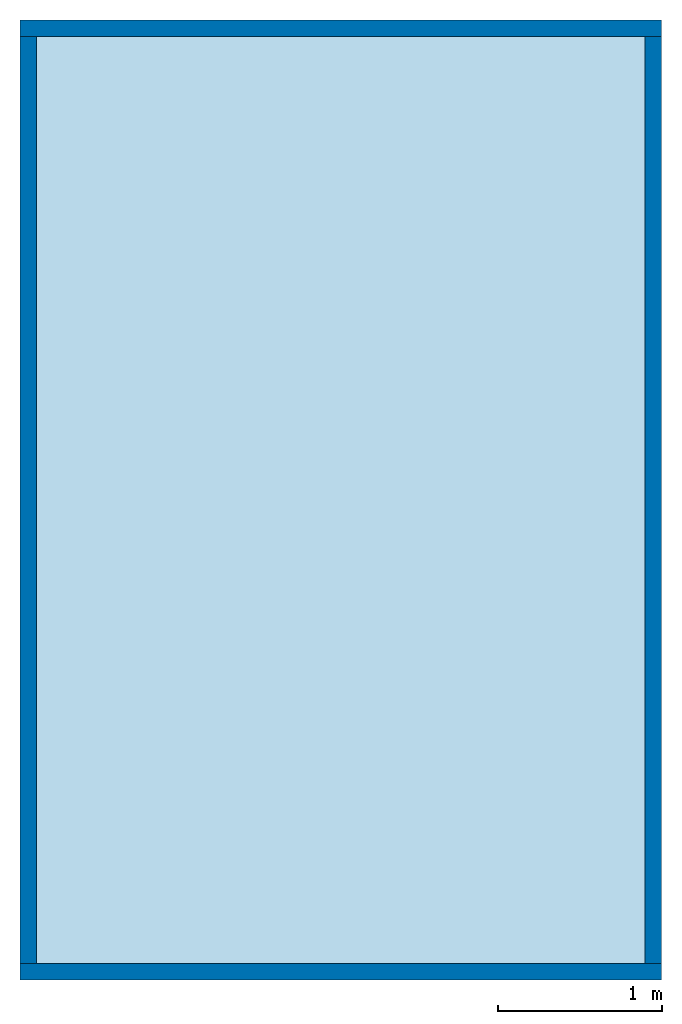
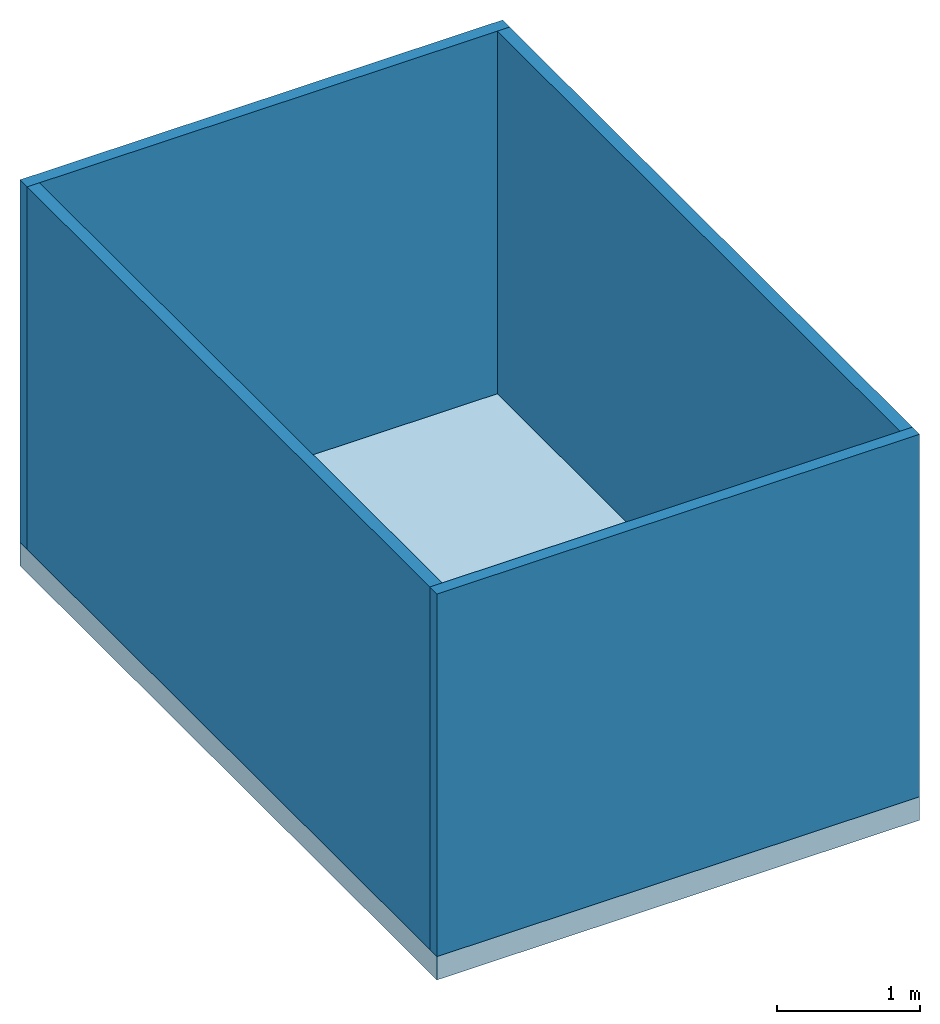
# One storey: 4 walls, 1 slab, 1 element without a shape of its own.
"""IFC4 building model written with IfcOpenShell, lengths in metres."""

from ifc_helpers import new_model, entity, si_unit, converted_unit, frame, origin_with_axes, origin_2d_with_axis, place, context, subcontext, project, spatial, line, indexed_curve, outline, extrude, clip, halfspace, material, layer, layer_set, layer_usage, type_object, element, aggregate, save


model = new_model("IFC4")

# Units and contexts
model_context = context("Model", 3, precision=1e-05, world=origin_with_axes())
plan_context = context("Plan", 2, precision=1e-05, world=origin_2d_with_axis())
body_context = subcontext(model_context, "Body", "Model", "MODEL_VIEW")
ifc_project = project(units=[si_unit("VOLUMEUNIT", "CUBIC_METRE"), si_unit("LENGTHUNIT", "METRE"), converted_unit("PLANEANGLEUNIT", "degree", entity("IfcReal", 0.0174532925199433), si_unit("PLANEANGLEUNIT", "RADIAN"), dimensions=[0, 0, 0, 0, 0, 0, 0]), si_unit("AREAUNIT", "SQUARE_METRE")], contexts=[model_context, plan_context])

# Site, building, storey
site_placement = place(None, origin_with_axes())
site = spatial("IfcSite", under=ifc_project, at=site_placement)
building_placement = place(site_placement, origin_with_axes())
building = spatial("IfcBuilding", under=site, at=building_placement, Name="Building")
storey_placement = place(building_placement, origin_with_axes())
storey = spatial("IfcBuildingStorey", under=building, at=storey_placement, Name="GF")

# Slab
ifc_material = material()
ifc_layer_1 = layer(ifc_material, 0.200000002980232)
ifc_layer_set_1 = layer_set([ifc_layer_1])
ifc_layer_usage_1 = layer_usage(ifc_layer_set_1, "AXIS3", "POSITIVE", 0.0)
slab_type = type_object("IfcSlabType", Name="slab", PredefinedType="FLOOR", material=ifc_layer_set_1)
slab_placement = place(storey_placement, frame((0.0, 0.0, -0.200000002980232), z_axis=(0.0, 0.0, 1.0), x_axis=(1.0, 0.0, 0.0)))
element("IfcSlab", 1, at=slab_placement, inside=storey, type_object=slab_type, material=ifc_layer_usage_1, Name="Slab", context=body_context, shape_type="SweptSolid", body=[
    extrude(outline(indexed_curve([(0.0, 0.0), (3.90270328521729, 0.0), (3.90270328521729, 5.84088945388794), (0.0, 5.84088945388794)], segments=[line(3, 2), line(2, 1), line(1, 4), line(4, 3)], self_intersect=False)), None, (0.0, 0.0, 1.0), 0.200000002980232),
])

# Assembly, walls
assembly_placement = place(storey_placement, origin_with_axes())
assembly = element("IfcElementAssembly", 2, at=assembly_placement, inside=storey)
ifc_layer_2 = layer(ifc_material, 0.1)
ifc_layer_set_2 = layer_set([ifc_layer_2])
ifc_layer_usage_2 = layer_usage(ifc_layer_set_2, "AXIS2", "POSITIVE", 0.0)
wall_type = type_object("IfcWallType", Name="wall", PredefinedType="SOLIDWALL", material=ifc_layer_set_2)
wall_1_placement = place(assembly_placement, origin_with_axes())
wall_1 = element("IfcWall", 3, at=wall_1_placement, type_object=wall_type, material=ifc_layer_usage_2, Name="Wall", context=body_context, shape_type="Clipping", body=[
    clip(extrude(outline(indexed_curve([(0.0, 0.0), (0.0, 0.1), (3.90270334597408, 0.1), (3.90270334597408, 0.0), (0.0, 0.0)], self_intersect=False)), origin_with_axes(), (0.0, 0.0, 1.0), 3.1000000984438), halfspace(frame((0.0, 0.0, 3.10000014305115), z_axis=(0.0, 0.0, 1.0), x_axis=(-1.0, 0.0, 0.0)), False)),
])
ifc_layer_usage_3 = layer_usage(ifc_layer_set_2, "AXIS2", "POSITIVE", 0.0)
wall_2_placement = place(assembly_placement, frame((0.0, 5.74088954925537, 0.0), z_axis=(0.0, 0.0, 1.0), x_axis=(1.0, 0.0, 0.0)))
wall_2 = element("IfcWall", 4, at=wall_2_placement, type_object=wall_type, material=ifc_layer_usage_3, Name="Wall", context=body_context, shape_type="Clipping", body=[
    clip(extrude(outline(indexed_curve([(0.0, 0.0), (0.0, 0.1), (3.90270334597408, 0.1), (3.90270334597408, 0.0), (0.0, 0.0)], self_intersect=False)), origin_with_axes(), (0.0, 0.0, 1.0), 3.1000000984438), halfspace(frame((0.0, 0.0, 3.10000014305115), z_axis=(0.0, 0.0, 1.0), x_axis=(-1.0, 0.0, 0.0)), False)),
])
ifc_layer_usage_4 = layer_usage(ifc_layer_set_2, "AXIS2", "POSITIVE", 0.0)
wall_3_placement = place(assembly_placement, frame((1.71551732819353e-06, 5.74088954925537, 0.0), z_axis=(0.0, 0.0, 1.0), x_axis=(-2.82129974493717e-07, -0.99999999999996, 0.0)))
wall_3 = element("IfcWall", 5, at=wall_3_placement, type_object=wall_type, material=ifc_layer_usage_4, Name="Wall", context=body_context, shape_type="Clipping", body=[
    clip(extrude(outline(indexed_curve([(0.0, 0.0), (0.0, 0.1), (5.6408890849929, 0.1), (5.6408890849929, 0.0), (0.0, 0.0)], self_intersect=False)), origin_with_axes(), (0.0, 0.0, 1.0), 3.1000000984438), halfspace(frame((-4.84057238736568e-13, 0.0, 3.10000014305115), z_axis=(0.0, 0.0, 1.0), x_axis=(-1.0, 0.0, 0.0)), False)),
])
ifc_layer_usage_5 = layer_usage(ifc_layer_set_2, "AXIS2", "POSITIVE", 0.0)
wall_4_placement = place(assembly_placement, frame((3.80270481109619, 5.74088954925537, 0.0), z_axis=(0.0, 0.0, 1.0), x_axis=(-2.82129974493717e-07, -0.99999999999996, 0.0)))
wall_4 = element("IfcWall", 6, at=wall_4_placement, type_object=wall_type, material=ifc_layer_usage_5, Name="Wall", context=body_context, shape_type="Clipping", body=[
    clip(extrude(outline(indexed_curve([(0.0, 0.0), (0.0, 0.1), (5.64088908499292, 0.1), (5.64088908499292, 0.0), (0.0, 0.0)], self_intersect=False)), origin_with_axes(), (0.0, 0.0, 1.0), 3.1000000984438), halfspace(frame((-1.19182686830754e-07, 4.92530034534866e-08, 3.10000014305115), z_axis=(0.0, 0.0, 1.0), x_axis=(-1.0, 0.0, 0.0)), False)),
])
aggregate(assembly, [wall_1, wall_2, wall_3, wall_4])

save(model, "model.ifc")
